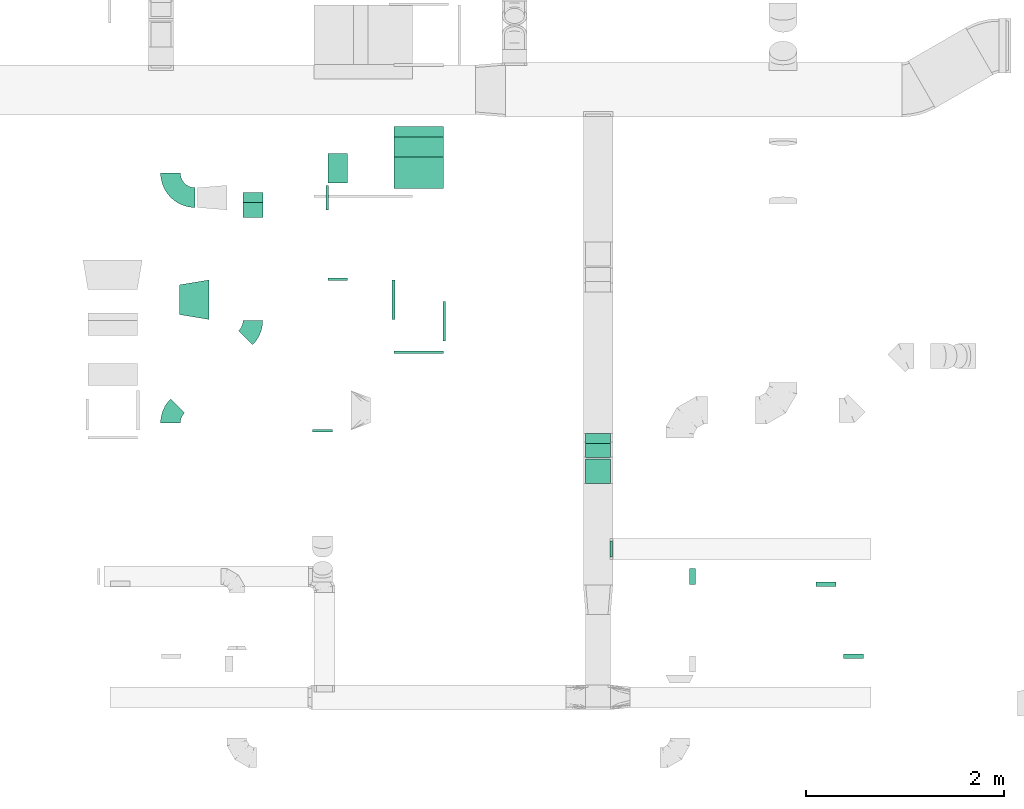
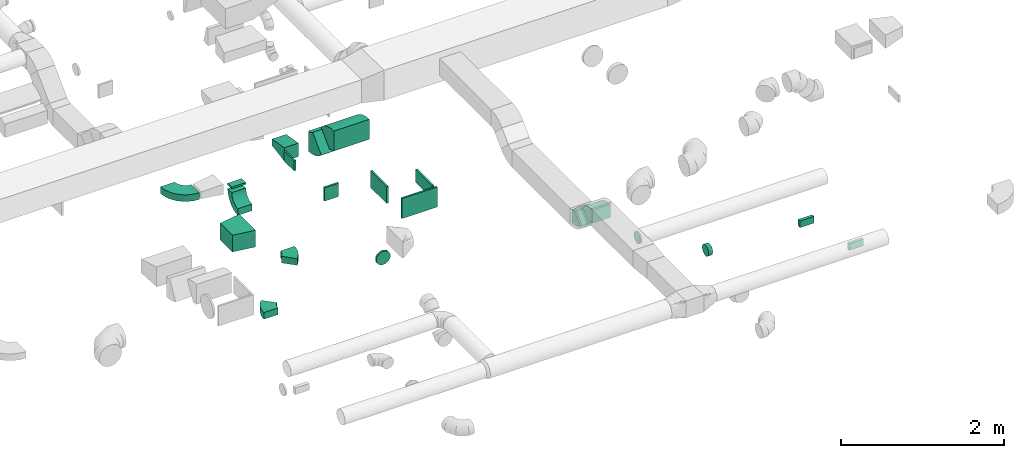
# One storey, part 38 of 62: 21 flow fittings.
"""IFC2X3 building model written with IfcOpenShell, lengths in millimetres."""

from ifc_helpers import new_model, entity, si_unit, converted_unit, derived_unit, direction, frame, frame_2d, origin, origin_2d_with_axis, place, context, subcontext, project, spatial, polyline, circle_curve, parameter, trimmed, segment, composite_curve, rectangle, outline, extrude, faceted_brep, source, transform, mapped, material, type_object, type_shapes, element, save


model = new_model("IFC2X3")

# Units and contexts
model_context = context("Model", 3, precision=0.01, world=origin(), true_north=direction((6.12303176911189e-17, 1.0)))
body_context = subcontext(model_context, "Body", "Model", "MODEL_VIEW")
ifc_project = project(units=[si_unit("LENGTHUNIT", "METRE", prefix="MILLI"), si_unit("AREAUNIT", "SQUARE_METRE"), si_unit("VOLUMEUNIT", "CUBIC_METRE"), converted_unit("PLANEANGLEUNIT", "DEGREE", entity("IfcRatioMeasure", 0.0174532925199433), si_unit("PLANEANGLEUNIT", "RADIAN"), dimensions=[0, 0, 0, 0, 0, 0, 0]), si_unit("MASSUNIT", "GRAM", prefix="KILO"), derived_unit("MASSDENSITYUNIT", [(si_unit("MASSUNIT", "GRAM", prefix="KILO"), 1), (si_unit("LENGTHUNIT", "METRE"), -3)]), derived_unit("MOMENTOFINERTIAUNIT", [(si_unit("LENGTHUNIT", "METRE"), 4)]), si_unit("TIMEUNIT", "SECOND"), si_unit("FREQUENCYUNIT", "HERTZ"), si_unit("THERMODYNAMICTEMPERATUREUNIT", "DEGREE_CELSIUS"), derived_unit("THERMALTRANSMITTANCEUNIT", [(si_unit("MASSUNIT", "GRAM", prefix="KILO"), 1), (si_unit("THERMODYNAMICTEMPERATUREUNIT", "KELVIN"), -1), (si_unit("TIMEUNIT", "SECOND"), -3)]), derived_unit("VOLUMETRICFLOWRATEUNIT", [(si_unit("LENGTHUNIT", "METRE"), 3), (si_unit("TIMEUNIT", "SECOND"), -1)]), derived_unit("MASSFLOWRATEUNIT", [(si_unit("MASSUNIT", "GRAM", prefix="KILO"), 1), (si_unit("TIMEUNIT", "SECOND"), -1)]), derived_unit("ROTATIONALFREQUENCYUNIT", [(si_unit("TIMEUNIT", "SECOND"), -1)]), si_unit("ELECTRICCURRENTUNIT", "AMPERE"), si_unit("ELECTRICVOLTAGEUNIT", "VOLT"), si_unit("POWERUNIT", "WATT"), si_unit("FORCEUNIT", "NEWTON", prefix="KILO"), si_unit("ILLUMINANCEUNIT", "LUX"), si_unit("LUMINOUSFLUXUNIT", "LUMEN"), si_unit("LUMINOUSINTENSITYUNIT", "CANDELA"), derived_unit("USERDEFINED", [(si_unit("MASSUNIT", "GRAM", prefix="KILO"), -1), (si_unit("LENGTHUNIT", "METRE"), -2), (si_unit("TIMEUNIT", "SECOND"), 3), (si_unit("LUMINOUSFLUXUNIT", "LUMEN"), 1)]), derived_unit("LINEARVELOCITYUNIT", [(si_unit("LENGTHUNIT", "METRE"), 1), (si_unit("TIMEUNIT", "SECOND"), -1)]), si_unit("PRESSUREUNIT", "PASCAL"), derived_unit("USERDEFINED", [(si_unit("LENGTHUNIT", "METRE"), -2), (si_unit("MASSUNIT", "GRAM", prefix="KILO"), 1), (si_unit("TIMEUNIT", "SECOND"), -2)]), derived_unit("LINEARFORCEUNIT", [(si_unit("MASSUNIT", "GRAM", prefix="KILO"), 1), (si_unit("LENGTHUNIT", "METRE"), 1), (si_unit("TIMEUNIT", "SECOND"), -2), (si_unit("LENGTHUNIT", "METRE"), -1)]), derived_unit("PLANARFORCEUNIT", [(si_unit("MASSUNIT", "GRAM", prefix="KILO"), 1), (si_unit("LENGTHUNIT", "METRE"), 1), (si_unit("TIMEUNIT", "SECOND"), -2), (si_unit("LENGTHUNIT", "METRE"), -2)])], contexts=[model_context])

# Site, building, storey
site_placement = place(None, origin())
site = spatial("IfcSite", under=ifc_project, at=site_placement, CompositionType="ELEMENT")
building_placement = place(site_placement, origin())
building = spatial("IfcBuilding", under=site, at=building_placement, CompositionType="ELEMENT")
storey_placement = place(building_placement, frame((0.0, 0.0, 24000.0)))
storey = spatial("IfcBuildingStorey", under=building, at=storey_placement, CompositionType="ELEMENT", Elevation=24000.0)

# Flow fittings
ifc_material = material()
duct_fitting_type_1 = type_object("IfcDuctFittingType", PredefinedType="NOTDEFINED", material=ifc_material)
shared_shape_1 = source(origin(), body_context, "Body", "SweptSolid", [
    extrude(rectangle(XDim=26.0960000000436, YDim=200.0, at=origin_2d_with_axis()), frame((6.95, 0.0, -100.0)), (0.0, 0.0, 1.0), 200.0),
])
type_shapes(duct_fitting_type_1, [shared_shape_1])
flow_fitting_1_placement = place(storey_placement, frame((52545.02, 6999.99, 3550.0), z_axis=(0.0, 0.0, -1.0), x_axis=(0.0, 1.0, 0.0)))
element("IfcFlowFitting", 1, at=flow_fitting_1_placement, inside=storey, type_object=duct_fitting_type_1, material=ifc_material, context=body_context, shape_type="MappedRepresentation", body=[
    mapped(shared_shape_1, transform((0.0, 0.0, 0.0), scale=1.0)),
])
duct_fitting_type_2 = type_object("IfcDuctFittingType", PredefinedType="NOTDEFINED", material=ifc_material)
shared_shape_2 = source(origin(), body_context, "Body", "SweptSolid", [
    extrude(rectangle(XDim=43.646020016021, YDim=200.0, at=origin_2d_with_axis()), frame((-1.82, 0.0, -50.0)), (0.0, 0.0, 1.0), 100.0),
])
type_shapes(duct_fitting_type_2, [shared_shape_2])
flow_fitting_2_placement = place(storey_placement, frame((57487.09, 3918.31, 3250.0), z_axis=(0.0, 0.0, -1.0), x_axis=(0.0, -1.0, 0.0)))
element("IfcFlowFitting", 2, at=flow_fitting_2_placement, inside=storey, type_object=duct_fitting_type_2, material=ifc_material, context=body_context, shape_type="MappedRepresentation", body=[
    mapped(shared_shape_2, transform((0.0, 0.0, 0.0), scale=1.0)),
])
duct_fitting_type_3 = type_object("IfcDuctFittingType", PredefinedType="NOTDEFINED", material=ifc_material)
shared_shape_3 = source(origin(), body_context, "Body", "SweptSolid", [
    extrude(rectangle(XDim=200.0, YDim=43.6460200160158, at=origin_2d_with_axis()), frame((-1.82, 0.0, -50.0), z_axis=(0.0, 0.0, 1.0), x_axis=(0.0, -1.0, 0.0)), (0.0, 0.0, 1.0), 100.0),
])
type_shapes(duct_fitting_type_3, [shared_shape_3])
flow_fitting_3_placement = place(storey_placement, frame((57764.94, 3194.24, 3250.0), z_axis=(0.0, 0.0, -1.0), x_axis=(0.0, 1.0, 0.0)))
element("IfcFlowFitting", 3, at=flow_fitting_3_placement, inside=storey, type_object=duct_fitting_type_3, material=ifc_material, context=body_context, shape_type="MappedRepresentation", body=[
    mapped(shared_shape_3, transform((0.0, 0.0, 0.0), scale=1.0)),
])
duct_fitting_type_4 = type_object("IfcDuctFittingType", PredefinedType="NOTDEFINED", material=ifc_material)
shared_shape_4 = source(origin(), body_context, "Body", "SweptSolid", [
    extrude(rectangle(XDim=400.0, YDim=26.096, at=origin_2d_with_axis()), frame((6.95, 0.0, -100.0), z_axis=(0.0, 0.0, 1.0), x_axis=(0.0, -1.0, 0.0)), (0.0, 0.0, 1.0), 200.0),
])
type_shapes(duct_fitting_type_4, [shared_shape_4])
flow_fitting_4_placement = place(storey_placement, frame((53615.82, 6580.41, 3550.0), z_axis=(0.0, 0.0, -1.0), x_axis=(1.0, 0.0, 0.0)))
element("IfcFlowFitting", 4, at=flow_fitting_4_placement, inside=storey, type_object=duct_fitting_type_4, material=ifc_material, context=body_context, shape_type="MappedRepresentation", body=[
    mapped(shared_shape_4, transform((0.0, 0.0, 0.0), scale=1.0)),
])
duct_fitting_type_5 = type_object("IfcDuctFittingType", PredefinedType="NOTDEFINED", material=ifc_material)
shared_shape_5 = source(origin(), body_context, "Body", "SweptSolid", [
    extrude(rectangle(XDim=26.0960000000006, YDim=400.0, at=origin_2d_with_axis()), frame((6.95, 0.0, -125.0)), (0.0, 0.0, 1.0), 250.0),
])
type_shapes(duct_fitting_type_5, [shared_shape_5])
flow_fitting_5_placement = place(storey_placement, frame((53115.82, 6799.99, 3550.0), z_axis=(0.0, 0.0, -1.0), x_axis=(-1.0, 0.0, 0.0)))
element("IfcFlowFitting", 5, at=flow_fitting_5_placement, inside=storey, type_object=duct_fitting_type_5, material=ifc_material, context=body_context, shape_type="MappedRepresentation", body=[
    mapped(shared_shape_5, transform((0.0, 0.0, 0.0), scale=1.0)),
])
duct_fitting_type_6 = type_object("IfcDuctFittingType", PredefinedType="NOTDEFINED", material=ifc_material)
shared_shape_6 = source(origin(), body_context, "Body", "SweptSolid", [
    extrude(rectangle(XDim=24.9999999999999, YDim=500.0, at=origin_2d_with_axis()), frame((12.5, 0.0, -150.0)), (0.0, 0.0, 1.0), 300.0),
])
type_shapes(duct_fitting_type_6, [shared_shape_6])
flow_fitting_6_placement = place(storey_placement, frame((53365.82, 6282.55, 3550.0), z_axis=(0.0, 0.0, 1.0), x_axis=(0.0, -1.0, 0.0)))
element("IfcFlowFitting", 6, at=flow_fitting_6_placement, inside=storey, type_object=duct_fitting_type_6, material=ifc_material, context=body_context, shape_type="MappedRepresentation", body=[
    mapped(shared_shape_6, transform((0.0, 0.0, 0.0), scale=1.0)),
])
duct_fitting_type_7 = type_object("IfcDuctFittingType", PredefinedType="NOTDEFINED", material=ifc_material)
shared_shape_7 = source(origin(), body_context, "Body", "SweptSolid", [
    extrude(outline(polyline([(-139.74, -73.98), (164.4, -73.98), (131.52, 123.3), (-156.18, 24.66), (-139.74, -73.98)])), frame((150.0, -100.0, 0.0), z_axis=(0.0, 1.0, 0.0), x_axis=(0.986393923832159, 0.0, 0.164398987305264)), (0.0, 0.0, 1.0), 200.0),
])
type_shapes(duct_fitting_type_7, [shared_shape_7])
flow_fitting_7_placement = place(storey_placement, frame((52545.02, 8280.79, 3550.0), z_axis=(0.0, 0.0, 1.0), x_axis=(0.0, -1.0, 0.0)))
element("IfcFlowFitting", 7, at=flow_fitting_7_placement, inside=storey, type_object=duct_fitting_type_7, material=ifc_material, context=body_context, shape_type="MappedRepresentation", body=[
    mapped(shared_shape_7, transform((0.0, 0.0, 0.0), scale=1.0)),
])
duct_fitting_type_8 = type_object("IfcDuctFittingType", PredefinedType="NOTDEFINED", material=ifc_material)
shared_shape_8 = source(origin(), body_context, "Body", "SweptSolid", [
    extrude(rectangle(XDim=26.0960000000004, YDim=250.0, at=origin_2d_with_axis()), frame((6.95, 0.0, -75.0)), (0.0, 0.0, 1.0), 150.0),
])
type_shapes(duct_fitting_type_8, [shared_shape_8])
flow_fitting_8_placement = place(storey_placement, frame((52445.02, 7833.07, 3550.0), z_axis=(0.0, 0.0, -1.0), x_axis=(-1.0, 0.0, 0.0)))
element("IfcFlowFitting", 8, at=flow_fitting_8_placement, inside=storey, type_object=duct_fitting_type_8, material=ifc_material, context=body_context, shape_type="MappedRepresentation", body=[
    mapped(shared_shape_8, transform((0.0, 0.0, 0.0), scale=1.0)),
])
duct_fitting_type_9 = type_object("IfcDuctFittingType", PredefinedType="NOTDEFINED", material=ifc_material)
shared_shape_9 = source(origin(), body_context, "Body", "SweptSolid", [
    extrude(rectangle(XDim=200.0, YDim=26.096, at=origin_2d_with_axis()), frame((6.95, 0.0, -50.0), z_axis=(0.0, 0.0, 1.0), x_axis=(0.0, -1.0, 0.0)), (0.0, 0.0, 1.0), 100.0),
])
type_shapes(duct_fitting_type_9, [shared_shape_9])
flow_fitting_9_placement = place(storey_placement, frame((51686.05, 7833.07, 3475.0), z_axis=(0.0, -1.0, 0.0), x_axis=(0.0, 0.0, -1.0)))
element("IfcFlowFitting", 9, at=flow_fitting_9_placement, inside=storey, type_object=duct_fitting_type_9, material=ifc_material, context=body_context, shape_type="MappedRepresentation", body=[
    mapped(shared_shape_9, transform((0.0, 0.0, 0.0), scale=1.0)),
])
duct_fitting_type_10 = type_object("IfcDuctFittingType", PredefinedType="NOTDEFINED", material=ifc_material)
shared_shape_10 = source(origin(), body_context, "Body", "SweptSolid", [
    extrude(outline(polyline([(-123.3, -172.62), (180.84, -172.62), (115.08, 221.94), (-172.62, 123.3), (-123.3, -172.62)])), frame((150.0, 0.0, -125.0), z_axis=(0.0, 0.0, 1.0), x_axis=(0.986393923832143, -0.164398987305359, 0.0)), (0.0, 0.0, 1.0), 250.0),
])
type_shapes(duct_fitting_type_10, [shared_shape_10])
flow_fitting_10_placement = place(storey_placement, frame((50940.82, 6799.99, 3550.0)))
element("IfcFlowFitting", 10, at=flow_fitting_10_placement, inside=storey, type_object=duct_fitting_type_10, material=ifc_material, context=body_context, shape_type="MappedRepresentation", body=[
    mapped(shared_shape_10, transform((0.0, 0.0, 0.0), scale=1.0)),
])
duct_fitting_type_11 = type_object("IfcDuctFittingType", PredefinedType="NOTDEFINED", material=ifc_material)
shared_shape_11 = source(origin(), body_context, "Body", "Brep", [
    faceted_brep([(20.0, 20.71, -77.27), (20.0, 40.0, -69.28), (20.0, 56.57, -56.57), (20.0, 69.28, -40.0), (20.0, 77.27, -20.71), (20.0, 80.0, 0.0), (20.0, 77.27, 20.71), (20.0, 69.28, 40.0), (20.0, 56.57, 56.57), (20.0, 40.0, 69.28), (20.0, 20.71, 77.27), (20.0, 0.0, 80.0), (20.0, -20.71, 77.27), (20.0, -40.0, 69.28), (20.0, -56.57, 56.57), (20.0, -69.28, 40.0), (20.0, -77.27, 20.71), (20.0, -80.0, 0.0), (20.0, -77.27, -20.71), (20.0, -69.28, -40.0), (20.0, -56.57, -56.57), (20.0, -40.0, -69.28), (20.0, -20.71, -77.27), (20.0, 0.0, -80.0), (0.0, 0.0, 80.0), (0.0, 20.71, 77.27), (-6.1, 20.71, 77.27), (-6.1, 0.0, 80.0), (0.0, 40.0, 69.28), (-6.1, 40.0, 69.28), (0.0, 56.57, 56.57), (-6.1, 56.57, 56.57), (0.0, 69.28, 40.0), (0.0, 77.27, 20.71), (-6.1, 77.27, 20.71), (-6.1, 69.28, 40.0), (0.0, 80.0, 0.0), (-6.1, 80.0, 0.0), (0.0, 77.27, -20.71), (-6.1, 77.27, -20.71), (0.0, 69.28, -40.0), (-6.1, 69.28, -40.0), (0.0, 56.57, -56.57), (-6.1, 56.57, -56.57), (0.0, 40.0, -69.28), (0.0, 20.71, -77.27), (-6.1, 20.71, -77.27), (-6.1, 40.0, -69.28), (0.0, 0.0, -80.0), (-6.1, 0.0, -80.0), (0.0, -20.71, -77.27), (-6.1, -20.71, -77.27), (0.0, -40.0, -69.28), (-6.1, -40.0, -69.28), (0.0, -56.57, -56.57), (-6.1, -56.57, -56.57), (0.0, -69.28, -40.0), (0.0, -77.27, -20.71), (-6.1, -77.27, -20.71), (-6.1, -69.28, -40.0), (0.0, -80.0, 0.0), (-6.1, -80.0, 0.0), (0.0, -77.27, 20.71), (-6.1, -77.27, 20.71), (0.0, -69.28, 40.0), (-6.1, -69.28, 40.0), (0.0, -56.57, 56.57), (-6.1, -56.57, 56.57), (0.0, -40.0, 69.28), (0.0, -20.71, 77.27), (-6.1, -20.71, 77.27), (-6.1, -40.0, 69.28)], [[[0, 1, 2, 3, 4, 5, 6, 7, 8, 9, 10, 11, 12, 13, 14, 15, 16, 17, 18, 19, 20, 21, 22, 23]], [[24, 11, 10, 25, 26, 27]], [[25, 10, 9, 28, 29, 26]], [[28, 9, 8, 30, 31, 29]], [[32, 7, 6, 33, 34, 35]], [[33, 6, 5, 36, 37, 34]], [[30, 8, 7, 32, 35, 31]], [[36, 5, 4, 38, 39, 37]], [[38, 4, 3, 40, 41, 39]], [[40, 3, 2, 42, 43, 41]], [[44, 1, 0, 45, 46, 47]], [[45, 0, 23, 48, 49, 46]], [[42, 2, 1, 44, 47, 43]], [[48, 23, 22, 50, 51, 49]], [[50, 22, 21, 52, 53, 51]], [[52, 21, 20, 54, 55, 53]], [[56, 19, 18, 57, 58, 59]], [[57, 18, 17, 60, 61, 58]], [[54, 20, 19, 56, 59, 55]], [[60, 17, 16, 62, 63, 61]], [[62, 16, 15, 64, 65, 63]], [[64, 15, 14, 66, 67, 65]], [[68, 13, 12, 69, 70, 71]], [[69, 12, 11, 24, 27, 70]], [[66, 14, 13, 68, 71, 67]], [[49, 51, 53, 55, 59, 58, 61, 63, 65, 67, 71, 70, 27, 26, 29, 31, 35, 34, 37, 39, 41, 43, 47, 46]]]),
])
type_shapes(duct_fitting_type_11, [shared_shape_11])
flow_fitting_11_placement = place(storey_placement, frame((55304.59, 4277.24, 3550.0), z_axis=(0.0, 0.0, -1.0), x_axis=(1.0, 0.0, 0.0)))
element("IfcFlowFitting", 11, at=flow_fitting_11_placement, inside=storey, type_object=duct_fitting_type_11, material=ifc_material, context=body_context, shape_type="MappedRepresentation", body=[
    mapped(shared_shape_11, transform((0.0, 0.0, 0.0), scale=1.0)),
])
duct_fitting_type_12 = type_object("IfcDuctFittingType", PredefinedType="NOTDEFINED", material=ifc_material)
shared_shape_12 = source(origin(), body_context, "Body", "Brep", [
    faceted_brep([(20.0, 0.0, -100.0), (20.0, 25.88, -96.59), (20.0, 50.0, -86.6), (20.0, 70.71, -70.71), (20.0, 86.6, -50.0), (20.0, 96.59, -25.88), (20.0, 100.0, 0.0), (20.0, 96.59, 25.88), (20.0, 86.6, 50.0), (20.0, 70.71, 70.71), (20.0, 50.0, 86.6), (20.0, 25.88, 96.59), (20.0, 0.0, 100.0), (20.0, -25.88, 96.59), (20.0, -50.0, 86.6), (20.0, -70.71, 70.71), (20.0, -86.6, 50.0), (20.0, -96.59, 25.88), (20.0, -100.0, 0.0), (20.0, -96.59, -25.88), (20.0, -86.6, -50.0), (20.0, -70.71, -70.71), (20.0, -50.0, -86.6), (20.0, -25.88, -96.59), (0.0, 0.0, 100.0), (-6.1, 0.0, 100.0), (-6.1, -25.88, 96.59), (0.0, -25.88, 96.59), (-6.1, -50.0, 86.6), (0.0, -50.0, 86.6), (0.0, -70.71, 70.71), (-6.1, -70.71, 70.71), (0.0, -86.6, 50.0), (-6.1, -86.6, 50.0), (-6.1, -96.59, 25.88), (0.0, -96.59, 25.88), (-6.1, -100.0, 0.0), (0.0, -100.0, 0.0), (-6.1, -96.59, -25.88), (0.0, -96.59, -25.88), (-6.1, -86.6, -50.0), (0.0, -86.6, -50.0), (0.0, -70.71, -70.71), (-6.1, -70.71, -70.71), (0.0, -50.0, -86.6), (-6.1, -50.0, -86.6), (-6.1, -25.88, -96.59), (0.0, -25.88, -96.59), (-6.1, 0.0, -100.0), (0.0, 0.0, -100.0), (-6.1, 25.88, -96.59), (0.0, 25.88, -96.59), (-6.1, 50.0, -86.6), (0.0, 50.0, -86.6), (0.0, 70.71, -70.71), (-6.1, 70.71, -70.71), (0.0, 86.6, -50.0), (-6.1, 86.6, -50.0), (-6.1, 96.59, -25.88), (0.0, 96.59, -25.88), (-6.1, 100.0, 0.0), (0.0, 100.0, 0.0), (-6.1, 96.59, 25.88), (0.0, 96.59, 25.88), (-6.1, 86.6, 50.0), (0.0, 86.6, 50.0), (0.0, 70.71, 70.71), (-6.1, 70.71, 70.71), (0.0, 50.0, 86.6), (-6.1, 50.0, 86.6), (-6.1, 25.88, 96.59), (0.0, 25.88, 96.59)], [[[0, 1, 2, 3, 4, 5, 6, 7, 8, 9, 10, 11, 12, 13, 14, 15, 16, 17, 18, 19, 20, 21, 22, 23]], [[13, 12, 24, 25, 26, 27]], [[14, 13, 27, 26, 28, 29]], [[30, 15, 14, 29, 28, 31]], [[17, 16, 32, 33, 34, 35]], [[18, 17, 35, 34, 36, 37]], [[32, 16, 15, 30, 31, 33]], [[19, 18, 37, 36, 38, 39]], [[20, 19, 39, 38, 40, 41]], [[42, 21, 20, 41, 40, 43]], [[23, 22, 44, 45, 46, 47]], [[0, 23, 47, 46, 48, 49]], [[44, 22, 21, 42, 43, 45]], [[1, 0, 49, 48, 50, 51]], [[2, 1, 51, 50, 52, 53]], [[54, 3, 2, 53, 52, 55]], [[5, 4, 56, 57, 58, 59]], [[6, 5, 59, 58, 60, 61]], [[56, 4, 3, 54, 55, 57]], [[7, 6, 61, 60, 62, 63]], [[8, 7, 63, 62, 64, 65]], [[66, 9, 8, 65, 64, 67]], [[11, 10, 68, 69, 70, 71]], [[12, 11, 71, 70, 25, 24]], [[68, 10, 9, 66, 67, 69]], [[46, 45, 43, 40, 38, 36, 34, 33, 31, 28, 26, 25, 70, 69, 67, 64, 62, 60, 58, 57, 55, 52, 50, 48]]]),
])
type_shapes(duct_fitting_type_12, [shared_shape_12])
flow_fitting_12_placement = place(storey_placement, frame((52391.36, 5480.28, 3550.0), z_axis=(0.0, 0.0, -1.0), x_axis=(0.0, -1.0, 0.0)))
element("IfcFlowFitting", 12, at=flow_fitting_12_placement, inside=storey, type_object=duct_fitting_type_12, material=ifc_material, context=body_context, shape_type="MappedRepresentation", body=[
    mapped(shared_shape_12, transform((0.0, 0.0, 0.0), scale=1.0)),
])
duct_fitting_type_13 = type_object("IfcDuctFittingType", PredefinedType="NOTDEFINED", material=ifc_material)
shared_shape_13 = source(origin(), body_context, "Body", "Brep", [
    faceted_brep([(20.02, 0.0, -80.0), (20.02, 20.71, -77.27), (20.02, 40.0, -69.28), (20.02, 56.57, -56.57), (20.02, 69.28, -40.0), (20.02, 77.27, -20.71), (20.02, 80.0, 0.0), (20.02, 77.27, 20.71), (20.02, 69.28, 40.0), (20.02, 56.57, 56.57), (20.02, 40.0, 69.28), (20.02, 20.71, 77.27), (20.02, 0.0, 80.0), (20.02, -20.71, 77.27), (20.02, -40.0, 69.28), (20.02, -56.57, 56.57), (20.02, -69.28, 40.0), (20.02, -77.27, 20.71), (20.02, -80.0, 0.0), (20.02, -77.27, -20.71), (20.02, -69.28, -40.0), (20.02, -56.57, -56.57), (20.02, -40.0, -69.28), (20.02, -20.71, -77.27), (0.0, 0.0, 80.0), (-38.52, 0.0, 80.0), (-38.52, -20.71, 77.27), (0.0, -20.71, 77.27), (-38.52, -40.0, 69.28), (0.0, -40.0, 69.28), (0.0, -56.57, 56.57), (-38.52, -56.57, 56.57), (0.0, -69.28, 40.0), (-38.52, -69.28, 40.0), (-38.52, -77.27, 20.71), (0.0, -77.27, 20.71), (-38.52, -80.0, 0.0), (0.0, -80.0, 0.0), (-38.52, -77.27, -20.71), (0.0, -77.27, -20.71), (-38.52, -69.28, -40.0), (0.0, -69.28, -40.0), (0.0, -56.57, -56.57), (-38.52, -56.57, -56.57), (0.0, -40.0, -69.28), (-38.52, -40.0, -69.28), (-38.52, -20.71, -77.27), (0.0, -20.71, -77.27), (-38.52, 0.0, -80.0), (0.0, 0.0, -80.0), (-38.52, 20.71, -77.27), (0.0, 20.71, -77.27), (-38.52, 40.0, -69.28), (0.0, 40.0, -69.28), (0.0, 56.57, -56.57), (-38.52, 56.57, -56.57), (0.0, 69.28, -40.0), (-38.52, 69.28, -40.0), (-38.52, 77.27, -20.71), (0.0, 77.27, -20.71), (-38.52, 80.0, 0.0), (0.0, 80.0, 0.0), (-38.52, 77.27, 20.71), (0.0, 77.27, 20.71), (-38.52, 69.28, 40.0), (0.0, 69.28, 40.0), (0.0, 56.57, 56.57), (-38.52, 56.57, 56.57), (0.0, 40.0, 69.28), (-38.52, 40.0, 69.28), (-38.52, 20.71, 77.27), (0.0, 20.71, 77.27)], [[[0, 1, 2, 3, 4, 5, 6, 7, 8, 9, 10, 11, 12, 13, 14, 15, 16, 17, 18, 19, 20, 21, 22, 23]], [[13, 12, 24, 25, 26, 27]], [[14, 13, 27, 26, 28, 29]], [[30, 15, 14, 29, 28, 31]], [[17, 16, 32, 33, 34, 35]], [[18, 17, 35, 34, 36, 37]], [[32, 16, 15, 30, 31, 33]], [[19, 18, 37, 36, 38, 39]], [[20, 19, 39, 38, 40, 41]], [[42, 21, 20, 41, 40, 43]], [[23, 22, 44, 45, 46, 47]], [[0, 23, 47, 46, 48, 49]], [[44, 22, 21, 42, 43, 45]], [[1, 0, 49, 48, 50, 51]], [[2, 1, 51, 50, 52, 53]], [[54, 3, 2, 53, 52, 55]], [[5, 4, 56, 57, 58, 59]], [[6, 5, 59, 58, 60, 61]], [[56, 4, 3, 54, 55, 57]], [[7, 6, 61, 60, 62, 63]], [[8, 7, 63, 62, 64, 65]], [[66, 9, 8, 65, 64, 67]], [[11, 10, 68, 69, 70, 71]], [[12, 11, 71, 70, 25, 24]], [[68, 10, 9, 66, 67, 69]], [[46, 45, 43, 40, 38, 36, 34, 33, 31, 28, 26, 25, 70, 69, 67, 64, 62, 60, 58, 57, 55, 52, 50, 48]]]),
])
type_shapes(duct_fitting_type_13, [shared_shape_13])
flow_fitting_13_placement = place(storey_placement, frame((56144.6, 3998.31, 3250.0), z_axis=(0.0, 0.0, -1.0), x_axis=(1.0, 0.0, 0.0)))
element("IfcFlowFitting", 13, at=flow_fitting_13_placement, inside=storey, type_object=duct_fitting_type_13, material=ifc_material, context=body_context, shape_type="MappedRepresentation", body=[
    mapped(shared_shape_13, transform((0.0, 0.0, 0.0), scale=1.0)),
])
duct_fitting_type_14 = type_object("IfcDuctFittingType", PredefinedType="NOTDEFINED", material=ifc_material)
shared_shape_14 = source(origin(), body_context, "Body", "SweptSolid", [
    extrude(outline(composite_curve([segment(polyline([(-193.93, -106.07), (106.07, -106.07)]), True, "CONTINUOUS"), segment(trimmed(circle_curve(frame_2d((256.07, -106.07), x_axis=(-0.707106781186553, 0.707106781186553)), 150.0), [parameter(0.0)], [parameter(45.0)], True, "PARAMETER"), False, "CONTINUOUS"), segment(polyline([(150.0, 0.0), (-62.13, 212.13)]), True, "CONTINUOUS"), segment(trimmed(circle_curve(frame_2d((256.07, -106.07), x_axis=(-0.707106781186553, 0.707106781186553)), 450.0), [parameter(0.0)], [parameter(45.0)], True, "PARAMETER"), True, "CONTINUOUS")], self_intersect=False)), frame((-18.2, 43.93, -250.0), z_axis=(0.0, 0.0, 1.0), x_axis=(-0.707106781186547, 0.707106781186548, 0.0)), (0.0, 0.0, 1.0), 500.0),
])
type_shapes(duct_fitting_type_14, [shared_shape_14])
for number, where, z_axis, x_axis in (
    (14, (53365.82, 8429.83, 3170.0), (-1.0, 0.0, 0.0), (0.0, -1.0, 0.0)),
    (15, (53365.82, 8049.83, 3550.0), (1.0, 0.0, 0.0), (0.0, -0.707106781186528, 0.707106781186567)),
):
    element("IfcFlowFitting", number, at=place(storey_placement, frame(where, z_axis=z_axis, x_axis=x_axis)), inside=storey, type_object=duct_fitting_type_14, material=ifc_material, context=body_context, shape_type="MappedRepresentation", body=[
        mapped(shared_shape_14, transform((0.0, 0.0, 0.0), scale=1.0)),
    ])
duct_fitting_type_15 = type_object("IfcDuctFittingType", PredefinedType="NOTDEFINED", material=ifc_material)
shared_shape_15 = source(origin(), body_context, "Body", "SweptSolid", [
    extrude(outline(composite_curve([segment(polyline([(-136.61, -88.39), (63.39, -88.39)]), True, "CONTINUOUS"), segment(trimmed(circle_curve(frame_2d((213.39, -88.39), x_axis=(-0.707106781186546, 0.707106781186546)), 150.0), [parameter(0.0)], [parameter(45.0)], True, "PARAMETER"), False, "CONTINUOUS"), segment(polyline([(107.32, 17.68), (-34.1, 159.1)]), True, "CONTINUOUS"), segment(trimmed(circle_curve(frame_2d((213.39, -88.39), x_axis=(-0.707106781186546, 0.707106781186546)), 350.0), [parameter(0.0)], [parameter(45.0)], True, "PARAMETER"), True, "CONTINUOUS")], self_intersect=False)), frame((-15.17, 36.61, -125.0), z_axis=(0.0, 0.0, 1.0), x_axis=(-0.707106781186547, 0.707106781186548, 0.0)), (0.0, 0.0, 1.0), 250.0),
])
type_shapes(duct_fitting_type_15, [shared_shape_15])
for number, where, z_axis, x_axis in (
    (16, (55179.59, 5044.86, 3550.0), (-1.0, 0.0, 0.0), (0.0, 1.0, 0.0)),
    (17, (55179.59, 5344.86, 3250.0), (1.0, 0.0, 0.0), (0.0, 0.707106781186519, -0.707106781186576)),
):
    element("IfcFlowFitting", number, at=place(storey_placement, frame(where, z_axis=z_axis, x_axis=x_axis)), inside=storey, type_object=duct_fitting_type_15, material=ifc_material, context=body_context, shape_type="MappedRepresentation", body=[
        mapped(shared_shape_15, transform((0.0, 0.0, 0.0), scale=1.0)),
    ])
duct_fitting_type_16 = type_object("IfcDuctFittingType", PredefinedType="NOTDEFINED", material=ifc_material)
shared_shape_16 = source(origin(), body_context, "Body", "SweptSolid", [
    extrude(outline(composite_curve([segment(polyline([(-150.0, -100.0), (-50.0, -100.0)]), True, "CONTINUOUS"), segment(trimmed(circle_curve(frame_2d((100.0, -100.0), x_axis=(0.0, 1.0)), 150.0), [parameter(0.0)], [parameter(90.0000000000001)], True, "PARAMETER"), False, "CONTINUOUS"), segment(polyline([(100.0, 50.0), (100.0, 150.0)]), True, "CONTINUOUS"), segment(trimmed(circle_curve(frame_2d((100.0, -100.0), x_axis=(0.0, 1.0)), 250.0), [parameter(0.0)], [parameter(90.0000000000001)], True, "PARAMETER"), True, "CONTINUOUS")], self_intersect=False)), frame((-100.0, 100.0, -100.0), z_axis=(0.0, 0.0, 1.0), x_axis=(-1.0, 0.0, 0.0)), (0.0, 0.0, 1.0), 200.0),
])
type_shapes(duct_fitting_type_16, [shared_shape_16])
flow_fitting_14_placement = place(storey_placement, frame((51686.05, 7833.07, 3200.0), z_axis=(-1.0, 0.0, 0.0), x_axis=(0.0, 0.0, -1.0)))
element("IfcFlowFitting", 18, at=flow_fitting_14_placement, inside=storey, type_object=duct_fitting_type_16, material=ifc_material, context=body_context, shape_type="MappedRepresentation", body=[
    mapped(shared_shape_16, transform((0.0, 0.0, 0.0), scale=1.0)),
])
duct_fitting_type_17 = type_object("IfcDuctFittingType", PredefinedType="NOTDEFINED", material=ifc_material)
shared_shape_17 = source(origin(), body_context, "Body", "SweptSolid", [
    extrude(outline(composite_curve([segment(polyline([(-225.0, -125.0), (-25.0, -125.0)]), True, "CONTINUOUS"), segment(trimmed(circle_curve(frame_2d((125.0, -125.0), x_axis=(0.0, 1.0)), 150.0), [parameter(0.0)], [parameter(90.0000000000001)], True, "PARAMETER"), False, "CONTINUOUS"), segment(polyline([(125.0, 25.0), (125.0, 225.0)]), True, "CONTINUOUS"), segment(trimmed(circle_curve(frame_2d((125.0, -125.0), x_axis=(0.0, 1.0)), 350.0), [parameter(0.0)], [parameter(90.0000000000001)], True, "PARAMETER"), True, "CONTINUOUS")], self_intersect=False)), frame((-125.0, 125.0, -50.0), z_axis=(0.0, 0.0, 1.0), x_axis=(-1.0, 0.0, 0.0)), (0.0, 0.0, 1.0), 100.0),
])
type_shapes(duct_fitting_type_17, [shared_shape_17])
flow_fitting_15_placement = place(storey_placement, frame((50851.67, 7833.07, 3550.0), z_axis=(0.0, 0.0, 1.0), x_axis=(0.0, -1.0, 0.0)))
element("IfcFlowFitting", 19, at=flow_fitting_15_placement, inside=storey, type_object=duct_fitting_type_17, material=ifc_material, context=body_context, shape_type="MappedRepresentation", body=[
    mapped(shared_shape_17, transform((0.0, 0.0, 0.0), scale=1.0)),
])
duct_fitting_type_18 = type_object("IfcDuctFittingType", PredefinedType="NOTDEFINED", material=ifc_material)
shared_shape_18 = source(origin(), body_context, "Body", "SweptSolid", [
    extrude(outline(composite_curve([segment(polyline([(-136.61, -88.39), (63.39, -88.39)]), True, "CONTINUOUS"), segment(trimmed(circle_curve(frame_2d((213.39, -88.39), x_axis=(-0.707106781186546, 0.707106781186546)), 150.0), [parameter(0.0)], [parameter(45.0)], True, "PARAMETER"), False, "CONTINUOUS"), segment(polyline([(107.32, 17.68), (-34.1, 159.1)]), True, "CONTINUOUS"), segment(trimmed(circle_curve(frame_2d((213.39, -88.39), x_axis=(-0.707106781186546, 0.707106781186546)), 350.0), [parameter(0.0)], [parameter(45.0)], True, "PARAMETER"), True, "CONTINUOUS")], self_intersect=False)), frame((-15.17, 36.61, -50.0), z_axis=(0.0, 0.0, 1.0), x_axis=(-0.707106781186547, 0.707106781186548, 0.0)), (0.0, 0.0, 1.0), 100.0),
])
type_shapes(duct_fitting_type_18, [shared_shape_18])
for number, where, z_axis, x_axis in (
    (20, (50851.67, 5653.68, 3200.0), (0.0, 0.0, 1.0), (-0.707106781186553, -0.707106781186542, 0.0)),
    (21, (51686.05, 6488.07, 3200.0), (0.0, 0.0, 1.0), (0.707106781186554, 0.707106781186541, 0.0)),
):
    element("IfcFlowFitting", number, at=place(storey_placement, frame(where, z_axis=z_axis, x_axis=x_axis)), inside=storey, type_object=duct_fitting_type_18, material=ifc_material, context=body_context, shape_type="MappedRepresentation", body=[
        mapped(shared_shape_18, transform((0.0, 0.0, 0.0), scale=1.0)),
    ])

save(model, "model.ifc")
